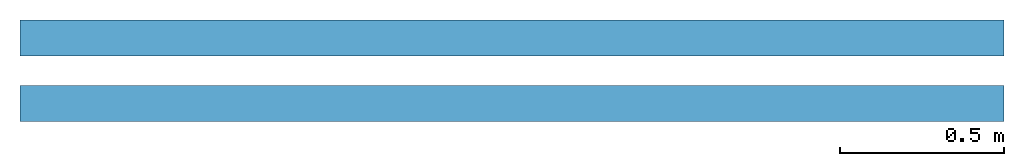
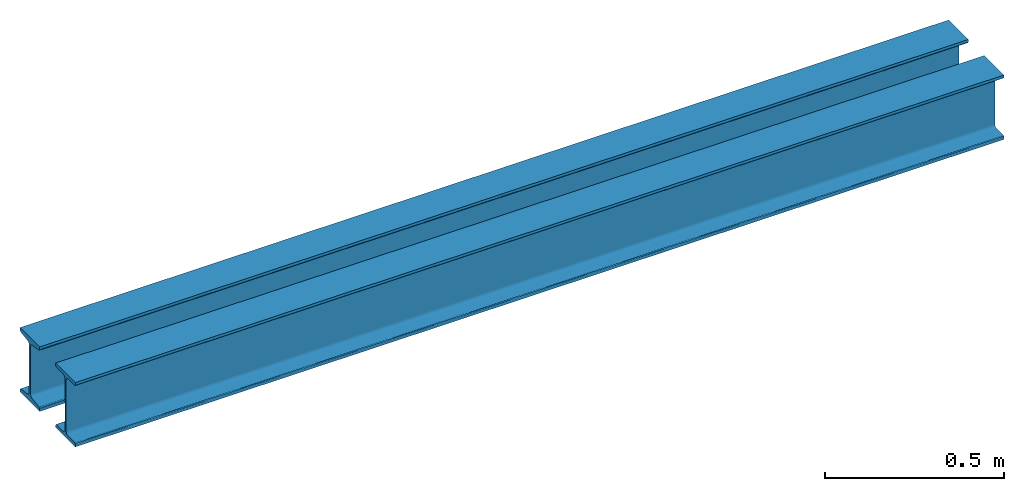
# One storey: 2 members.
"""IFC4 building model written with IfcOpenShell, lengths in millimetres."""

from ifc_helpers import new_model, entity, si_unit, converted_unit, frame, frame_2d, origin_with_axes, place, context, subcontext, project, spatial, i_section, extrude, material, material_profile, profile_set, profile_usage, element, save


model = new_model("IFC4")

# Units and contexts
model_context = context("Model", 3, precision=1e-05, world=origin_with_axes())
plan_context = context("Plan", 2, precision=1e-05, world=frame_2d((0.0, 0.0, 0.0), x_axis=(1.0, 0.0, 0.0)))
body_context = subcontext(model_context, "Body", "Model", "MODEL_VIEW")
ifc_project = project(units=[si_unit("LENGTHUNIT", "METRE", prefix="MILLI"), converted_unit("PLANEANGLEUNIT", "degree", entity("IfcReal", 0.0174532925199433), si_unit("PLANEANGLEUNIT", "RADIAN"), dimensions=[0, 0, 0, 0, 0, 0, 0]), si_unit("AREAUNIT", "SQUARE_METRE", prefix="MILLI"), si_unit("VOLUMEUNIT", "CUBIC_METRE", prefix="MILLI")], contexts=[model_context, plan_context])

# Site, building, storey
site_placement = place(None, origin_with_axes())
site = spatial("IfcSite", under=ifc_project, at=site_placement)
building_placement = place(site_placement, origin_with_axes())
building = spatial("IfcBuilding", under=site, at=building_placement, Name="Building")
storey_placement = place(building_placement, origin_with_axes())
storey = spatial("IfcBuildingStorey", under=building, at=storey_placement, Name="Storey")

# Members
ifc_material = material(Name="S345", Category="STEEL")
ifc_material_profile_1 = material_profile(ifc_material, i_section(OverallWidth=110.0, OverallDepth=220.0, WebThickness=7.5, FlangeThickness=12.3000001907349, FilletRadius=9.5, FlangeEdgeRadius=4.80000019073486, FlangeSlope=9.09000015258789))
ifc_profile_set_1 = profile_set([ifc_material_profile_1])
ifc_profile_usage_1 = profile_usage(ifc_profile_set_1)
member_1_placement = place(storey_placement, frame((0.0, 199.999988079071, 0.0), z_axis=(1.0, 1.62920741786365e-07, -4.01339264044509e-07), x_axis=(-1.62920684942947e-07, 1.0, 1.49011611938477e-07)))
element("IfcMember", 1, at=member_1_placement, inside=storey, material=ifc_profile_usage_1, Name="Member", PredefinedType="NOTDEFINED", context=body_context, shape_type="SweptSolid", body=[
    extrude(i_section(OverallWidth=110.0, OverallDepth=220.0, WebThickness=7.5, FlangeThickness=12.3000001907349, FilletRadius=9.5, FlangeEdgeRadius=4.80000019073486, FlangeSlope=9.09000015258789), frame((0.0, 300.0, 0.0), z_axis=(0.0, 0.0, 1.0), x_axis=(1.0, 0.0, 0.0)), (0.0, 0.0, 1.0), 3000.00000000028),
])
ifc_material_profile_2 = material_profile(ifc_material, i_section(OverallWidth=110.0, OverallDepth=220.0, WebThickness=7.5, FlangeThickness=12.3, FilletRadius=9.5, FlangeEdgeRadius=4.8, FlangeSlope=0.158655262186401))
ifc_profile_set_2 = profile_set([ifc_material_profile_2])
ifc_profile_usage_2 = profile_usage(ifc_profile_set_2)
member_2_placement = place(storey_placement, frame((0.0, 0.0, 0.0), z_axis=(1.0, 1.62920699153801e-07, -1.62920684942947e-07), x_axis=(-1.62920684942947e-07, 1.0, 1.19209275339927e-07)))
element("IfcMember", 2, at=member_2_placement, inside=storey, material=ifc_profile_usage_2, Name="Member", PredefinedType="NOTDEFINED", context=body_context, shape_type="SweptSolid", body=[
    extrude(i_section(OverallWidth=110.0, OverallDepth=220.0, WebThickness=7.5, FlangeThickness=12.3, FilletRadius=9.5, FlangeEdgeRadius=4.8, FlangeSlope=0.158655262186401), frame((0.0, 300.0, 0.0), z_axis=(0.0, 0.0, 1.0), x_axis=(1.0, 0.0, 0.0)), (0.0, 0.0, 1.0), 3000.00000000008),
])

save(model, "model.ifc")
